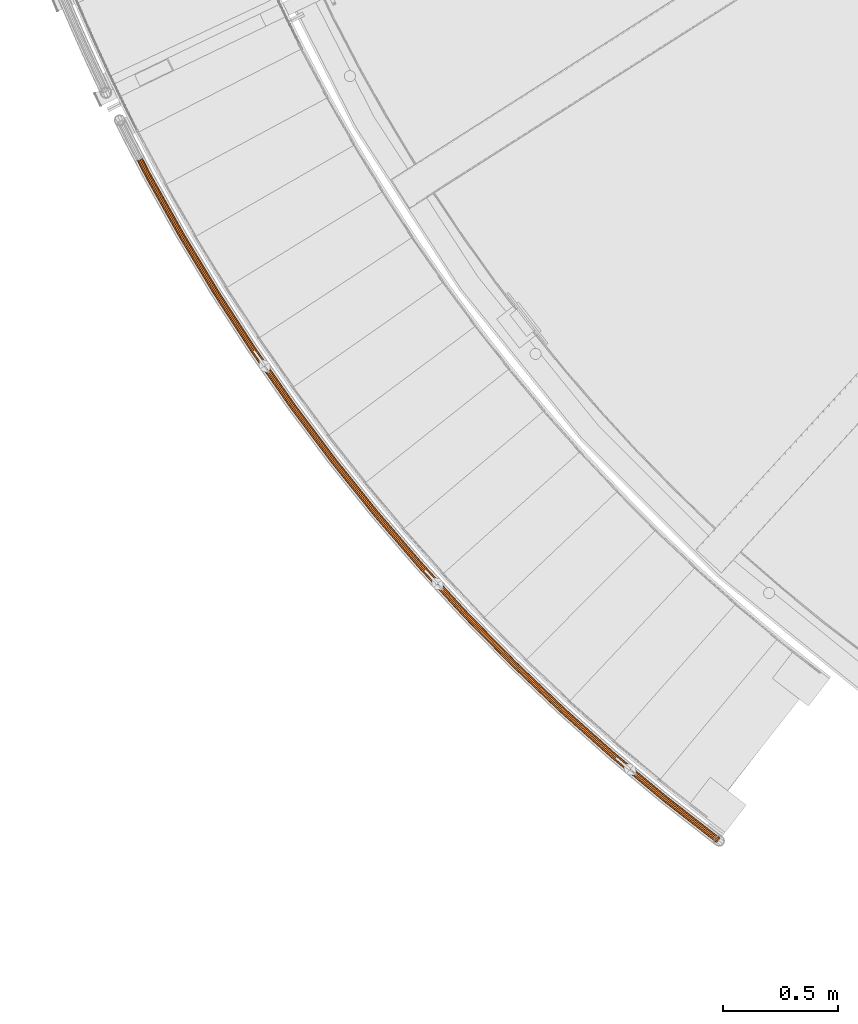
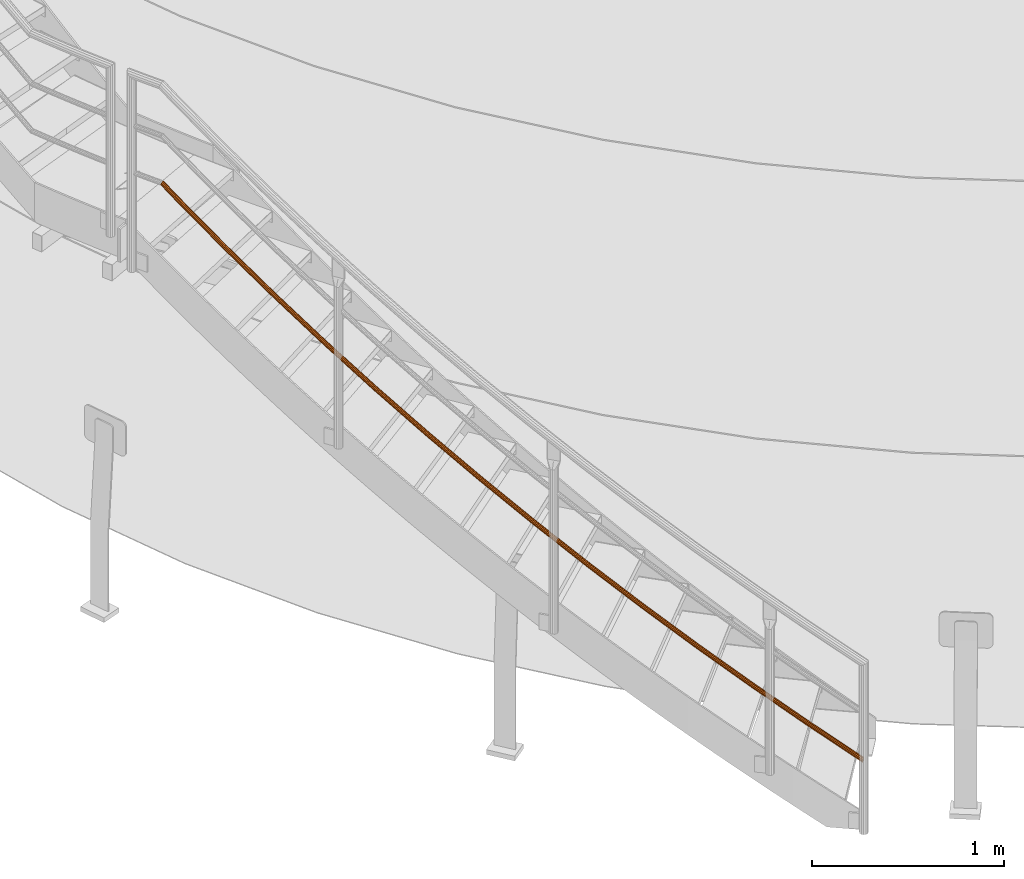
# One storey, part 6 of 126: 1 proxy.
"""IFC2X3 building model written with IfcOpenShell, lengths in millimetres."""

from ifc_helpers import new_model, si_unit, origin, origin_with_axes, place, context, project, spatial, faceted_brep, material, element, save


model = new_model("IFC2X3")

# Units and contexts
context_of_model_1 = context(None, 3, precision=0.1, world=origin())
context_of_model_2 = context(None, 3, precision=0.1, world=origin())
ifc_project = project(units=[si_unit("LENGTHUNIT", "METRE", prefix="MILLI"), si_unit("AREAUNIT", "SQUARE_METRE", prefix="CENTI"), si_unit("VOLUMEUNIT", "CUBIC_METRE", prefix="CENTI"), si_unit("MASSUNIT", "GRAM", prefix="KILO")], contexts=[context_of_model_1, context_of_model_2])

# Site, building, storey
site_placement = place(None, origin_with_axes())
site = spatial("IfcSite", under=ifc_project, at=site_placement, CompositionType="ELEMENT")
building_placement = place(site_placement, origin_with_axes())
building = spatial("IfcBuilding", under=site, at=building_placement, CompositionType="ELEMENT")
storey_placement = place(building_placement, origin_with_axes())
storey = spatial("IfcBuildingStorey", under=building, at=storey_placement, CompositionType="ELEMENT")

# Proxy
ifc_material = material(Name="S235JRG2")
proxy_placement = place(storey_placement, origin_with_axes())
element("IfcBuildingElementProxy", 1, at=proxy_placement, inside=storey, material=ifc_material, context=context_of_model_2, shape_type="Brep", body=[
    faceted_brep([(2668.0873, 927.5568, 454.3461), (2668.8892, 926.9738, 453.6473), (2665.4589, 922.5847, 455.6089), (2672.9419, 932.3419, 455.7662), (2673.033, 932.2757, 455.6869), (2673.1586, 932.4363, 455.9312), (2448.0601, 1099.3001, 683.9784), (2443.049, 1094.679, 682.5583), (2665.018, 922.0207, 484.5047), (2669.1783, 927.3437, 486.5512), (2437.7426, 1092.5724, 678.5731), (2661.9323, 918.0726, 478.6008), (2433.5626, 1093.5447, 673.0908), (2660.7465, 916.5554, 470.4216), (2431.629, 1097.3354, 667.5803), (2661.7775, 917.8745, 462.1562), (2432.46, 1102.9287, 663.5182), (2664.7498, 921.6775, 456.0166), (2435.8329, 1108.826, 661.9928), (2440.8438, 1113.447, 663.4129), (2446.1502, 1115.5536, 667.398), (2676.1205, 936.2261, 461.5903), (2450.3303, 1114.5814, 672.8803), (2677.3086, 937.7462, 469.7765), (2452.2639, 1110.7908, 678.3908), (2676.2757, 936.4246, 478.0493), (2451.4329, 1105.1975, 682.453), (2673.2992, 932.6163, 484.1893), (2447.151, 1100.0084, 682.3438), (2450.0223, 1105.0288, 681.0452), (2672.6644, 931.8041, 482.0937), (2669.1564, 927.3157, 484.1049), (2450.7297, 1109.7904, 677.587), (2675.198, 935.0457, 476.8667), (2449.0836, 1113.0173, 672.8959), (2676.0772, 936.1706, 469.8245), (2445.5251, 1113.845, 668.2289), (2675.0659, 934.8768, 462.8561), (2441.0078, 1112.0516, 664.8364), (2672.4358, 931.5115, 457.8304), (2436.742, 1108.1177, 663.6275), (2668.8926, 926.9781, 456.0941), (2433.8707, 1103.0974, 664.926), (2665.3863, 922.4918, 458.1103), (2433.1632, 1098.3358, 668.3841), (2662.8557, 919.254, 463.3369), (2434.8092, 1095.1088, 673.0752), (2661.9779, 918.1309, 470.3738), (2438.3677, 1094.281, 677.7423), (2662.9875, 919.4227, 477.3372), (2442.8851, 1096.0744, 681.1348), (2665.6146, 922.784, 482.3631), (2221.6347, 1287.7865, 891.6251), (2216.4728, 1283.3345, 890.205), (2211.0993, 1281.4054, 886.2198), (2206.9539, 1282.5161, 880.7375), (2205.1474, 1286.3689, 875.2271), (2206.1639, 1291.9315, 871.1649), (2209.7308, 1297.7134, 869.6396), (2214.8926, 1302.1653, 871.0597), (2220.2661, 1304.0945, 875.0447), (2224.4115, 1302.9839, 880.527), (2226.2181, 1299.1311, 886.0375), (2225.2017, 1293.5685, 890.0997), (2220.7496, 1288.5245, 889.9905), (2223.7862, 1293.4467, 888.692), (2224.6515, 1298.1822, 885.2338), (2223.1135, 1301.4621, 880.5427), (2219.5845, 1302.4076, 875.8756), (2215.0101, 1300.7653, 872.4831), (2210.6159, 1296.9753, 871.2742), (2207.5793, 1292.0532, 872.5727), (2206.714, 1287.3177, 876.0308), (2208.2519, 1284.0378, 880.7219), (2211.7809, 1283.0923, 885.389), (2216.3554, 1284.7345, 888.7816), (2001.5983, 1483.6934, 1099.2719), (1996.2913, 1479.4154, 1097.8517), (1990.8567, 1477.666, 1093.8666), (1986.7505, 1478.9138, 1088.3843), (1985.073, 1482.8246, 1082.8738), (1986.2738, 1488.3503, 1078.8117), (1990.0309, 1494.0105, 1077.2863), (1995.3378, 1498.2884, 1078.7064), (2000.7724, 1500.0379, 1082.6915), (2004.8786, 1498.7902, 1088.1738), (2006.5561, 1494.8795, 1093.6843), (2005.3555, 1489.3537, 1097.7465), (2000.7383, 1484.4605, 1097.6373), (2003.9368, 1489.2791, 1096.3387), (2004.9589, 1493.9832, 1092.8805), (2003.5308, 1497.3124, 1088.1894), (2000.0352, 1498.3746, 1083.5224), (1995.4087, 1496.8852, 1080.1299), (1990.8909, 1493.2434, 1078.921), (1987.6925, 1488.4249, 1080.2195), (1986.6703, 1483.7208, 1083.6776), (1988.0983, 1480.3916, 1088.3686), (1991.5939, 1479.3293, 1093.0357), (1996.2205, 1480.8186, 1096.4283), (1788.1939, 1686.8046, 1306.9186), (1782.7477, 1682.7053, 1305.4985), (1777.2579, 1681.1374, 1301.5133), (1773.1955, 1682.521, 1296.031), (1771.6489, 1686.4854, 1290.5206), (1773.0326, 1691.9682, 1286.4584), (1776.9758, 1697.5003, 1284.9331), (1782.4219, 1701.5996, 1286.3532), (1787.9116, 1703.1675, 1290.3382), (1791.9741, 1701.784, 1295.8205), (1793.5208, 1697.8197, 1301.331), (1792.1371, 1692.3369, 1305.3932), (1787.3599, 1687.5998, 1305.284), (1790.7167, 1692.3094, 1303.9854), (1791.8946, 1696.977, 1300.5273), (1790.578, 1700.3518, 1295.8362), (1787.1196, 1701.5296, 1291.1691), (1782.4461, 1700.1948, 1287.7766), (1777.8099, 1696.7051, 1286.5677), (1774.453, 1691.9956, 1287.8662), (1773.2751, 1687.328, 1291.3243), (1774.5917, 1683.9532, 1296.0154), (1778.05, 1682.7753, 1300.6825), (1782.7235, 1684.1101, 1304.0751), (1581.6574, 1896.8955, 1514.5654), (1576.078, 1892.9795, 1513.1452), (1570.5391, 1891.5949, 1509.1601), (1566.5249, 1893.1128, 1503.6778), (1565.1109, 1897.1263, 1498.1673), (1566.676, 1902.5601, 1494.1052), (1570.8009, 1907.9582, 1492.5798), (1576.3802, 1911.8742, 1493.9999), (1581.919, 1913.2588, 1497.985), (1585.9333, 1911.741, 1503.4672), (1587.3473, 1907.7275, 1508.9778), (1585.7823, 1902.2937, 1513.04), (1580.8502, 1897.718, 1512.9308), (1584.3617, 1902.3135, 1511.6322), (1585.6941, 1906.9393, 1508.174), (1584.4903, 1910.356, 1503.4829), (1581.0729, 1911.6481, 1498.8159), (1576.3577, 1910.4694, 1495.4234), (1571.6081, 1907.1357, 1494.2144), (1568.0966, 1902.5403, 1495.513), (1566.7642, 1897.9145, 1498.9711), (1567.9679, 1894.4978, 1503.6621), (1571.3852, 1893.2056, 1508.3292), (1576.1004, 1894.3843, 1511.7218), (1382.2168, 2113.7342, 1722.2121), (1376.5103, 2110.0057, 1720.792), (1370.9285, 2108.806, 1716.8068), (1366.9669, 2110.4564, 1711.3245), (1365.6871, 2114.5147, 1705.814), (1367.432, 2119.8935, 1701.7519), (1371.7339, 2125.1515, 1700.2266), (1377.4403, 2128.8799, 1701.6467), (1383.0221, 2130.0797, 1705.6317), (1386.9837, 2128.4294, 1711.114), (1388.2636, 2124.3711, 1716.6245), (1386.5188, 2118.9923, 1720.6867), (1381.4374, 2114.5831, 1720.5775), (1385.0997, 2119.0593, 1719.2789), (1386.585, 2123.6383, 1715.8208), (1385.4955, 2127.0931, 1711.1297), (1382.1229, 2128.498, 1706.4626), (1377.3711, 2127.4766, 1703.0701), (1372.5133, 2124.3026, 1701.8612), (1368.8511, 2119.8265, 1703.1597), (1367.3657, 2115.2475, 1706.6178), (1368.4551, 2111.7927, 1711.3089), (1371.8276, 2110.3877, 1715.976), (1376.5795, 2111.409, 1719.3686), (1190.0924, 2337.081, 1929.8589), (1184.2652, 2333.5443, 1928.4387), (1178.6466, 2332.5307, 1924.4536), (1174.7421, 2334.3119, 1918.9713), (1173.5979, 2338.4105, 1913.4608), (1175.5205, 2343.7283, 1909.3987), (1179.9948, 2348.8404, 1907.8733), (1185.8219, 2352.3771, 1909.2934), (1191.4405, 2353.3907, 1913.2785), (1195.3451, 2351.6097, 1918.7607), (1196.4894, 2347.5111, 1924.2713), (1194.5668, 2342.1933, 1928.3335), (1189.3417, 2337.9553, 1928.2243), (1193.1507, 2342.3074, 1926.9257), (1194.7874, 2346.8345, 1923.4675), (1193.8133, 2350.3236, 1918.7764), (1190.4893, 2351.8398, 1914.1094), (1185.7062, 2350.9769, 1910.7169), (1180.7456, 2347.9661, 1909.5079), (1176.9366, 2343.6141, 1910.8065), (1175.2998, 2339.0871, 1914.2646), (1176.2739, 2335.5979, 1918.9556), (1179.5978, 2334.0816, 1923.6227), (1184.381, 2334.9445, 1927.0153), (1005.4967, 2566.6893, 2137.5056), (999.5551, 2563.3481, 2136.0855), (993.9059, 2562.5218, 2132.1003), (990.0627, 2564.4318, 2126.618), (989.0554, 2568.5661, 2121.1075), (991.1537, 2573.8171, 2117.0454), (995.7954, 2578.7777, 2115.5201), (1001.7368, 2582.1188, 2116.9402), (1007.386, 2582.9452, 2120.9252), (1011.2292, 2581.0354, 2126.4075), (1012.2367, 2576.901, 2131.918), (1010.1385, 2571.65, 2135.9802), (1004.7754, 2567.588, 2135.871), (1008.7269, 2571.8111, 2134.5724), (1010.5132, 2576.2813, 2131.1143), (1009.6555, 2579.8009, 2126.4232), (1006.3838, 2581.4267, 2121.7561), (1001.5746, 2580.7233, 2118.3636), (996.5167, 2577.879, 2117.1547), (992.5652, 2573.656, 2118.4532), (990.7789, 2569.1858, 2121.9113), (991.6365, 2565.6662, 2126.6024), (994.9082, 2564.0403, 2131.2695), (999.7173, 2564.7437, 2134.662), (828.6333, 2802.3053, 2345.1524), (822.584, 2799.1635, 2343.7322), (816.9105, 2798.5254, 2339.7471), (813.1329, 2800.562, 2334.2648), (812.2635, 2804.7275, 2328.7543), (814.5351, 2809.9059, 2324.6922), (819.3392, 2814.7095, 2323.1668), (825.3883, 2817.8513, 2324.5869), (831.0618, 2818.4895, 2328.572), (834.8395, 2816.453, 2334.0542), (835.709, 2812.2874, 2339.5647), (833.4374, 2807.109, 2343.627), (827.9423, 2803.2276, 2343.5178), (832.032, 2807.317, 2342.2192), (833.9658, 2811.7253, 2338.761), (833.2256, 2815.2715, 2334.0699), (830.0097, 2817.0051, 2329.4029), (825.1799, 2816.4619, 2326.0104), (820.0302, 2813.7873, 2324.8014), (815.9405, 2809.6979, 2326.1), (814.0066, 2805.2896, 2329.5581), (814.7468, 2801.7434, 2334.2491), (817.9626, 2800.0097, 2338.9162), (822.7925, 2800.5529, 2342.3088), (659.6978, 3043.6688, 2552.7991), (653.5475, 3040.7298, 2551.379), (647.8558, 3040.2806, 2547.3938), (644.148, 3042.4416, 2541.9115), (643.4175, 3046.6337, 2536.401), (645.86, 3051.7337, 2532.3389), (650.821, 3056.375, 2530.8136), (656.9713, 3059.3141, 2532.2337), (662.6628, 3059.7633, 2536.2187), (666.3707, 3057.6024, 2541.701), (667.1013, 3053.4103, 2547.2115), (664.6589, 3048.3103, 2551.2737), (659.0378, 3044.6135, 2551.1645), (663.2612, 3048.5648, 2549.8659), (665.3405, 3052.9065, 2546.4078), (664.7185, 3056.4752, 2541.7167), (661.562, 3058.3148, 2537.0496), (656.7167, 3057.9324, 2533.6571), (651.481, 3055.4303, 2532.4482), (647.2577, 3051.4792, 2533.7467), (645.1784, 3047.1375, 2537.2048), (645.8003, 3043.5688, 2541.8959), (648.9567, 3041.7291, 2546.563), (653.802, 3042.1115, 2549.9555), (498.8768, 3290.5132, 2760.4459), (492.6321, 3287.7802, 2759.0257), (486.9287, 3287.5204, 2755.0406), (483.2948, 3289.8034, 2749.5582), (482.704, 3294.0175, 2744.0478), (485.3146, 3299.0335, 2739.9857), (490.4271, 3303.5074, 2738.4603), (496.6717, 3306.2404, 2739.8804), (502.375, 3306.5003, 2743.8655), (506.009, 3304.2174, 2749.3477), (506.5999, 3300.0033, 2754.8582), (503.9894, 3294.9872, 2758.9205), (498.2486, 3291.4793, 2758.8113), (502.6009, 3295.288, 2757.5127), (504.8233, 3299.5582, 2754.0545), (504.3203, 3303.1457, 2749.3634), (501.2266, 3305.0892, 2744.6964), (496.3713, 3304.8679, 2741.3039), (491.0554, 3302.5413, 2740.0949), (486.7031, 3298.7327, 2741.3935), (484.4806, 3294.4625, 2744.8516), (484.9836, 3290.8751, 2749.5426), (488.0772, 3288.9315, 2754.2097), (492.9325, 3289.1527, 2757.6023), (346.3479, 3542.5658, 2968.0926), (340.0158, 3540.0417, 2966.6725), (334.307, 3539.9716, 2962.6873), (330.7509, 3542.3742, 2957.205), (330.3005, 3546.6056, 2951.6945), (333.0764, 3551.5321, 2947.6324), (338.3347, 3555.8336, 2946.1071), (344.6666, 3558.3576, 2947.5272), (350.3755, 3558.4278, 2951.5122), (353.9316, 3556.0253, 2956.9945), (354.3821, 3551.7939, 2962.505), (351.6063, 3546.8674, 2966.5672), (345.7521, 3543.5522, 2966.458), (350.2286, 3547.2142, 2965.1594), (352.5917, 3551.4081, 2961.7013), (352.2081, 3555.0103, 2957.0102), (349.1808, 3557.0556, 2952.3431), (344.3208, 3556.9958, 2948.9506), (338.9305, 3554.8471, 2947.7417), (334.454, 3551.1852, 2949.0402), (332.0909, 3546.9913, 2952.4983), (332.4744, 3543.3891, 2957.1894), (335.5017, 3541.3438, 2961.8565), (340.3616, 3541.4035, 2965.249), (202.2796, 3799.548, 3175.7394), (195.8672, 3797.2358, 3174.3192), (190.1591, 3797.3555, 3170.3341), (186.6848, 3799.8749, 3164.8517), (186.3753, 3804.1189, 3159.3413), (189.3134, 3808.9504, 3155.2792), (194.7118, 3813.0748, 3153.7538), (201.1241, 3815.387, 3155.1739), (206.8321, 3815.2674, 3159.159), (210.3064, 3812.7481, 3164.6412), (210.6161, 3808.5041, 3170.1517), (207.6781, 3803.6725, 3174.214), (201.7169, 3800.5537, 3174.1047), (206.3126, 3804.0649, 3172.8062), (208.8138, 3808.178, 3169.348), (208.5502, 3811.791, 3164.6569), (205.5925, 3813.9357, 3159.9898), (200.7332, 3814.0375, 3156.5974), (195.2744, 3812.0691, 3155.3884), (190.6788, 3808.558, 3156.687), (188.1776, 3804.4449, 3160.145), (188.4411, 3800.832, 3164.8361), (191.3987, 3798.6872, 3169.5032), (196.258, 3798.5854, 3172.8958), (161.8002, 3877.7368, 3237.7956), (155.5033, 3875.2232, 3236.1649), (150.327, 3874.375, 3231.368), (147.6574, 3875.4191, 3224.6906), (148.209, 3878.0756, 3217.9208), (151.8342, 3881.6332, 3212.8717), (157.5627, 3885.1392, 3210.8959), (163.8602, 3887.6541, 3212.5237), (169.0391, 3888.5037, 3217.3201), (171.7107, 3887.4598, 3223.9999), (171.1585, 3884.802, 3230.7725), (167.5307, 3881.2429, 3235.8221), (161.4858, 3878.2875, 3235.7956), (166.3641, 3881.2723, 3234.1154), (169.4523, 3884.302, 3229.8167), (169.9224, 3886.5645, 3224.0514), (167.6481, 3887.4532, 3218.365), (163.2395, 3886.7301, 3214.2818), (157.8785, 3884.5892, 3212.8959), (153.0017, 3881.6046, 3214.5777), (149.9154, 3878.5759, 3218.8761), (149.4458, 3876.3143, 3224.6393), (151.7186, 3875.4255, 3230.324), (156.1253, 3876.1476, 3234.4075)], [[[0, 1, 2]], [[0, 3, 4, 1]], [[3, 5, 4]], [[6, 7, 8, 9]], [[7, 10, 11, 8]], [[10, 12, 13, 11]], [[12, 14, 15, 13]], [[14, 16, 17, 15]], [[17, 16, 18, 0, 2]], [[0, 18, 19, 3]], [[3, 19, 20, 21, 5]], [[20, 22, 23, 21]], [[22, 24, 25, 23]], [[24, 26, 27, 25]], [[6, 9, 27, 26]], [[28, 29, 30, 31]], [[29, 32, 33, 30]], [[32, 34, 35, 33]], [[34, 36, 37, 35]], [[36, 38, 39, 37]], [[38, 40, 41, 39]], [[40, 42, 43, 41]], [[42, 44, 45, 43]], [[44, 46, 47, 45]], [[46, 48, 49, 47]], [[48, 50, 51, 49]], [[28, 31, 51, 50]], [[6, 52, 53, 7]], [[7, 53, 54, 10]], [[10, 54, 55, 12]], [[12, 55, 56, 14]], [[14, 56, 57, 16]], [[16, 57, 58, 18]], [[18, 58, 59, 19]], [[19, 59, 60, 20]], [[20, 60, 61, 22]], [[22, 61, 62, 24]], [[24, 62, 63, 26]], [[26, 63, 52, 6]], [[28, 64, 65, 29]], [[29, 65, 66, 32]], [[32, 66, 67, 34]], [[34, 67, 68, 36]], [[36, 68, 69, 38]], [[38, 69, 70, 40]], [[40, 70, 71, 42]], [[42, 71, 72, 44]], [[44, 72, 73, 46]], [[46, 73, 74, 48]], [[48, 74, 75, 50]], [[50, 75, 64, 28]], [[52, 76, 77, 53]], [[53, 77, 78, 54]], [[54, 78, 79, 55]], [[55, 79, 80, 56]], [[56, 80, 81, 57]], [[57, 81, 82, 58]], [[58, 82, 83, 59]], [[59, 83, 84, 60]], [[60, 84, 85, 61]], [[61, 85, 86, 62]], [[62, 86, 87, 63]], [[63, 87, 76, 52]], [[64, 88, 89, 65]], [[65, 89, 90, 66]], [[66, 90, 91, 67]], [[67, 91, 92, 68]], [[68, 92, 93, 69]], [[69, 93, 94, 70]], [[70, 94, 95, 71]], [[71, 95, 96, 72]], [[72, 96, 97, 73]], [[73, 97, 98, 74]], [[74, 98, 99, 75]], [[75, 99, 88, 64]], [[76, 100, 101, 77]], [[77, 101, 102, 78]], [[78, 102, 103, 79]], [[79, 103, 104, 80]], [[80, 104, 105, 81]], [[81, 105, 106, 82]], [[82, 106, 107, 83]], [[83, 107, 108, 84]], [[84, 108, 109, 85]], [[85, 109, 110, 86]], [[86, 110, 111, 87]], [[87, 111, 100, 76]], [[88, 112, 113, 89]], [[89, 113, 114, 90]], [[90, 114, 115, 91]], [[91, 115, 116, 92]], [[92, 116, 117, 93]], [[93, 117, 118, 94]], [[94, 118, 119, 95]], [[95, 119, 120, 96]], [[96, 120, 121, 97]], [[97, 121, 122, 98]], [[98, 122, 123, 99]], [[99, 123, 112, 88]], [[100, 124, 125, 101]], [[101, 125, 126, 102]], [[102, 126, 127, 103]], [[103, 127, 128, 104]], [[104, 128, 129, 105]], [[105, 129, 130, 106]], [[106, 130, 131, 107]], [[107, 131, 132, 108]], [[108, 132, 133, 109]], [[109, 133, 134, 110]], [[110, 134, 135, 111]], [[111, 135, 124, 100]], [[112, 136, 137, 113]], [[113, 137, 138, 114]], [[114, 138, 139, 115]], [[115, 139, 140, 116]], [[116, 140, 141, 117]], [[117, 141, 142, 118]], [[118, 142, 143, 119]], [[119, 143, 144, 120]], [[120, 144, 145, 121]], [[121, 145, 146, 122]], [[122, 146, 147, 123]], [[123, 147, 136, 112]], [[124, 148, 149, 125]], [[125, 149, 150, 126]], [[126, 150, 151, 127]], [[127, 151, 152, 128]], [[128, 152, 153, 129]], [[129, 153, 154, 130]], [[130, 154, 155, 131]], [[131, 155, 156, 132]], [[132, 156, 157, 133]], [[133, 157, 158, 134]], [[134, 158, 159, 135]], [[135, 159, 148, 124]], [[136, 160, 161, 137]], [[137, 161, 162, 138]], [[138, 162, 163, 139]], [[139, 163, 164, 140]], [[140, 164, 165, 141]], [[141, 165, 166, 142]], [[142, 166, 167, 143]], [[143, 167, 168, 144]], [[144, 168, 169, 145]], [[145, 169, 170, 146]], [[146, 170, 171, 147]], [[147, 171, 160, 136]], [[148, 172, 173, 149]], [[149, 173, 174, 150]], [[150, 174, 175, 151]], [[151, 175, 176, 152]], [[152, 176, 177, 153]], [[153, 177, 178, 154]], [[154, 178, 179, 155]], [[155, 179, 180, 156]], [[156, 180, 181, 157]], [[157, 181, 182, 158]], [[158, 182, 183, 159]], [[159, 183, 172, 148]], [[160, 184, 185, 161]], [[161, 185, 186, 162]], [[162, 186, 187, 163]], [[163, 187, 188, 164]], [[164, 188, 189, 165]], [[165, 189, 190, 166]], [[166, 190, 191, 167]], [[167, 191, 192, 168]], [[168, 192, 193, 169]], [[169, 193, 194, 170]], [[170, 194, 195, 171]], [[171, 195, 184, 160]], [[172, 196, 197, 173]], [[173, 197, 198, 174]], [[174, 198, 199, 175]], [[175, 199, 200, 176]], [[176, 200, 201, 177]], [[177, 201, 202, 178]], [[178, 202, 203, 179]], [[179, 203, 204, 180]], [[180, 204, 205, 181]], [[181, 205, 206, 182]], [[182, 206, 207, 183]], [[183, 207, 196, 172]], [[184, 208, 209, 185]], [[185, 209, 210, 186]], [[186, 210, 211, 187]], [[187, 211, 212, 188]], [[188, 212, 213, 189]], [[189, 213, 214, 190]], [[190, 214, 215, 191]], [[191, 215, 216, 192]], [[192, 216, 217, 193]], [[193, 217, 218, 194]], [[194, 218, 219, 195]], [[195, 219, 208, 184]], [[196, 220, 221, 197]], [[197, 221, 222, 198]], [[198, 222, 223, 199]], [[199, 223, 224, 200]], [[200, 224, 225, 201]], [[201, 225, 226, 202]], [[202, 226, 227, 203]], [[203, 227, 228, 204]], [[204, 228, 229, 205]], [[205, 229, 230, 206]], [[206, 230, 231, 207]], [[207, 231, 220, 196]], [[208, 232, 233, 209]], [[209, 233, 234, 210]], [[210, 234, 235, 211]], [[211, 235, 236, 212]], [[212, 236, 237, 213]], [[213, 237, 238, 214]], [[214, 238, 239, 215]], [[215, 239, 240, 216]], [[216, 240, 241, 217]], [[217, 241, 242, 218]], [[218, 242, 243, 219]], [[219, 243, 232, 208]], [[220, 244, 245, 221]], [[221, 245, 246, 222]], [[222, 246, 247, 223]], [[223, 247, 248, 224]], [[224, 248, 249, 225]], [[225, 249, 250, 226]], [[226, 250, 251, 227]], [[227, 251, 252, 228]], [[228, 252, 253, 229]], [[229, 253, 254, 230]], [[230, 254, 255, 231]], [[231, 255, 244, 220]], [[232, 256, 257, 233]], [[233, 257, 258, 234]], [[234, 258, 259, 235]], [[235, 259, 260, 236]], [[236, 260, 261, 237]], [[237, 261, 262, 238]], [[238, 262, 263, 239]], [[239, 263, 264, 240]], [[240, 264, 265, 241]], [[241, 265, 266, 242]], [[242, 266, 267, 243]], [[243, 267, 256, 232]], [[244, 268, 269, 245]], [[245, 269, 270, 246]], [[246, 270, 271, 247]], [[247, 271, 272, 248]], [[248, 272, 273, 249]], [[249, 273, 274, 250]], [[250, 274, 275, 251]], [[251, 275, 276, 252]], [[252, 276, 277, 253]], [[253, 277, 278, 254]], [[254, 278, 279, 255]], [[255, 279, 268, 244]], [[256, 280, 281, 257]], [[257, 281, 282, 258]], [[258, 282, 283, 259]], [[259, 283, 284, 260]], [[260, 284, 285, 261]], [[261, 285, 286, 262]], [[262, 286, 287, 263]], [[263, 287, 288, 264]], [[264, 288, 289, 265]], [[265, 289, 290, 266]], [[266, 290, 291, 267]], [[267, 291, 280, 256]], [[268, 292, 293, 269]], [[269, 293, 294, 270]], [[270, 294, 295, 271]], [[271, 295, 296, 272]], [[272, 296, 297, 273]], [[273, 297, 298, 274]], [[274, 298, 299, 275]], [[275, 299, 300, 276]], [[276, 300, 301, 277]], [[277, 301, 302, 278]], [[278, 302, 303, 279]], [[279, 303, 292, 268]], [[280, 304, 305, 281]], [[281, 305, 306, 282]], [[282, 306, 307, 283]], [[283, 307, 308, 284]], [[284, 308, 309, 285]], [[285, 309, 310, 286]], [[286, 310, 311, 287]], [[287, 311, 312, 288]], [[288, 312, 313, 289]], [[289, 313, 314, 290]], [[290, 314, 315, 291]], [[291, 315, 304, 280]], [[292, 316, 317, 293]], [[293, 317, 318, 294]], [[294, 318, 319, 295]], [[295, 319, 320, 296]], [[296, 320, 321, 297]], [[297, 321, 322, 298]], [[298, 322, 323, 299]], [[299, 323, 324, 300]], [[300, 324, 325, 301]], [[301, 325, 326, 302]], [[302, 326, 327, 303]], [[303, 327, 316, 292]], [[304, 328, 329, 305]], [[305, 329, 330, 306]], [[306, 330, 331, 307]], [[307, 331, 332, 308]], [[308, 332, 333, 309]], [[309, 333, 334, 310]], [[310, 334, 335, 311]], [[311, 335, 336, 312]], [[312, 336, 337, 313]], [[313, 337, 338, 314]], [[314, 338, 339, 315]], [[315, 339, 328, 304]], [[316, 340, 341, 317]], [[317, 341, 342, 318]], [[318, 342, 343, 319]], [[319, 343, 344, 320]], [[320, 344, 345, 321]], [[321, 345, 346, 322]], [[322, 346, 347, 323]], [[323, 347, 348, 324]], [[324, 348, 349, 325]], [[325, 349, 350, 326]], [[326, 350, 351, 327]], [[316, 327, 351, 340]], [[328, 352, 353, 329]], [[329, 353, 354, 330]], [[330, 354, 355, 331]], [[331, 355, 356, 332]], [[332, 356, 357, 333]], [[333, 357, 358, 334]], [[334, 358, 359, 335]], [[335, 359, 360, 336]], [[336, 360, 361, 337]], [[337, 361, 362, 338]], [[338, 362, 363, 339]], [[328, 339, 363, 352]], [[340, 351, 350, 349, 348, 347, 346, 345, 344, 343, 342, 341], [352, 363, 362, 361, 360, 359, 358, 357, 356, 355, 354, 353]], [[13, 15, 17, 2, 1, 4, 5, 21, 23, 25, 27, 9, 8, 11], [30, 33, 35, 37, 39, 41, 43, 45, 47, 49, 51, 31]]]),
])

save(model, "model.ifc")
